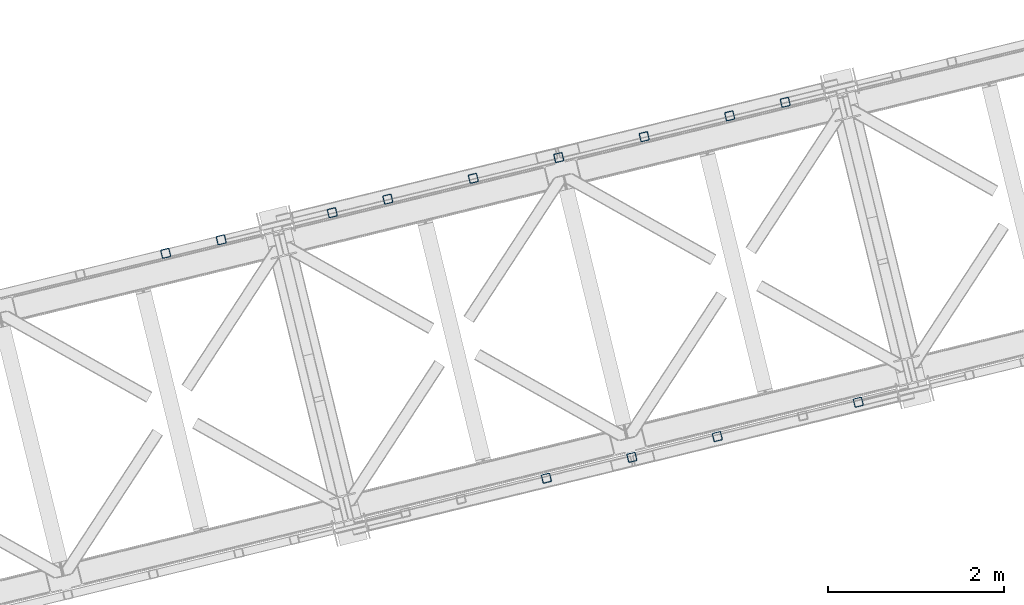
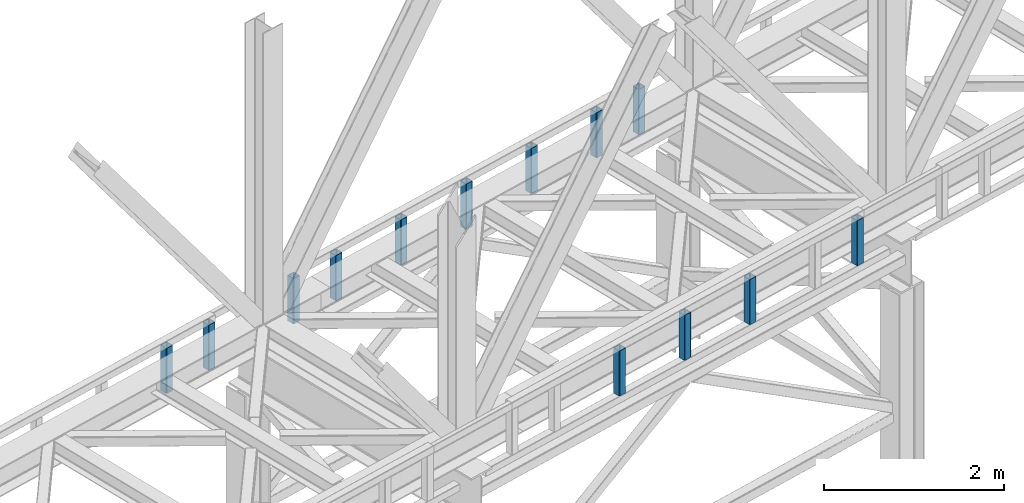
# One storey, part 7 of 93: 13 columns.
"""IFC4 building model written with IfcOpenShell, lengths in millimetres."""

from ifc_helpers import new_model, entity, si_unit, converted_unit, derived_unit, direction, frame, origin, place, context, subcontext, project, spatial, indexed_curve, outline, extrude, type_object, element, save


model = new_model("IFC4")

# Units and contexts
model_context = context("Model", 3, precision=0.01, world=origin(), true_north=direction((6.12303176911189e-17, 1.0)))
plan_context = context("Plan", 3, precision=0.01, world=origin(), true_north=direction((6.12303176911189e-17, 1.0)))
body_context = subcontext(model_context, "Body", "Model", "MODEL_VIEW")
ifc_project = project(units=[si_unit("LENGTHUNIT", "METRE", prefix="MILLI"), si_unit("AREAUNIT", "SQUARE_METRE"), si_unit("VOLUMEUNIT", "CUBIC_METRE"), converted_unit("PLANEANGLEUNIT", "DEGREE", entity("IfcRatioMeasure", 0.0174532925199433), si_unit("PLANEANGLEUNIT", "RADIAN"), dimensions=[0, 0, 0, 0, 0, 0, 0]), si_unit("MASSUNIT", "GRAM", prefix="KILO"), derived_unit("MASSDENSITYUNIT", [(si_unit("MASSUNIT", "GRAM", prefix="KILO"), 1), (si_unit("LENGTHUNIT", "METRE"), -3)]), derived_unit("MOMENTOFINERTIAUNIT", [(si_unit("LENGTHUNIT", "METRE"), 4)]), si_unit("TIMEUNIT", "SECOND"), si_unit("FREQUENCYUNIT", "HERTZ"), si_unit("THERMODYNAMICTEMPERATUREUNIT", "DEGREE_CELSIUS"), derived_unit("THERMALTRANSMITTANCEUNIT", [(si_unit("MASSUNIT", "GRAM", prefix="KILO"), 1), (si_unit("THERMODYNAMICTEMPERATUREUNIT", "KELVIN"), -1), (si_unit("TIMEUNIT", "SECOND"), -3)]), derived_unit("VOLUMETRICFLOWRATEUNIT", [(si_unit("LENGTHUNIT", "METRE"), 3), (si_unit("TIMEUNIT", "SECOND"), -1)]), derived_unit("MASSFLOWRATEUNIT", [(si_unit("MASSUNIT", "GRAM", prefix="KILO"), 1), (si_unit("TIMEUNIT", "SECOND"), -1)]), derived_unit("ROTATIONALFREQUENCYUNIT", [(si_unit("TIMEUNIT", "SECOND"), -1)]), si_unit("ELECTRICCURRENTUNIT", "AMPERE"), si_unit("ELECTRICVOLTAGEUNIT", "VOLT"), si_unit("POWERUNIT", "WATT"), si_unit("FORCEUNIT", "NEWTON", prefix="KILO"), si_unit("ILLUMINANCEUNIT", "LUX"), si_unit("LUMINOUSFLUXUNIT", "LUMEN"), si_unit("LUMINOUSINTENSITYUNIT", "CANDELA"), derived_unit("USERDEFINED", [(si_unit("MASSUNIT", "GRAM", prefix="KILO"), -1), (si_unit("LENGTHUNIT", "METRE"), -2), (si_unit("TIMEUNIT", "SECOND"), 3), (si_unit("LUMINOUSFLUXUNIT", "LUMEN"), 1)]), derived_unit("LINEARVELOCITYUNIT", [(si_unit("LENGTHUNIT", "METRE"), 1), (si_unit("TIMEUNIT", "SECOND"), -1)]), si_unit("PRESSUREUNIT", "PASCAL"), derived_unit("USERDEFINED", [(si_unit("LENGTHUNIT", "METRE"), -2), (si_unit("MASSUNIT", "GRAM", prefix="KILO"), 1), (si_unit("TIMEUNIT", "SECOND"), -2)]), derived_unit("LINEARFORCEUNIT", [(si_unit("MASSUNIT", "GRAM", prefix="KILO"), 1), (si_unit("LENGTHUNIT", "METRE"), 1), (si_unit("TIMEUNIT", "SECOND"), -2), (si_unit("LENGTHUNIT", "METRE"), -1)]), derived_unit("PLANARFORCEUNIT", [(si_unit("MASSUNIT", "GRAM", prefix="KILO"), 1), (si_unit("LENGTHUNIT", "METRE"), 1), (si_unit("TIMEUNIT", "SECOND"), -2), (si_unit("LENGTHUNIT", "METRE"), -2)])], contexts=[model_context, plan_context])

# Site, building, storey
site_placement = place(None, origin())
site = spatial("IfcSite", under=ifc_project, at=site_placement, CompositionType="ELEMENT")
building_placement = place(site_placement, origin())
building = spatial("IfcBuilding", under=site, at=building_placement, CompositionType="ELEMENT")
storey_placement = place(building_placement, frame((0.0, 0.0, 15900.0)))
storey = spatial("IfcBuildingStorey", under=building, at=storey_placement, CompositionType="ELEMENT", Elevation=15900.0)

# Columns
column_type_1 = type_object("IfcColumnType", PredefinedType="COLUMN")
column_1_placement = place(storey_placement, origin())
element("IfcColumn", 1, at=column_1_placement, inside=storey, type_object=column_type_1, ObjectType="Steel Column", PredefinedType="COLUMN", context=body_context, shape_type="SweptSolid", body=[
    extrude(outline(indexed_curve([(29.4768951153029, -56.8428769008198), (33.3787015556228, -56.8428769008198), (36.9835006656554, -55.3497202198148), (39.7424944584929, -52.5907264269884), (41.2356511394991, -48.9859273169536), (56.84287690082, 29.4768951152981), (56.8428769008277, 33.3787015556192), (55.3497202198129, 36.9835006656563), (52.5907264269925, 39.7424944584862), (48.9859273169586, 41.2356511394944), (-29.4768951152941, 56.8428769008181), (-33.3787015556141, 56.8428769008181), (-36.9835006656505, 55.349720219815), (-39.7424944584793, 52.5907264269869), (-41.2356511394904, 48.9859273169519), (-56.8428769008112, -29.4768951152997), (-56.842876900815, -33.3787015556227), (-55.3497202198089, -36.9835006656581), (-52.5907264269837, -39.7424944584879), (-48.9859273169498, -41.2356511394961), (29.4768951153029, -56.8428769008198)], self_intersect=False), holes=[indexed_curve([(-43.1065493048517, -37.307176347563), (-46.7113484148808, -35.8140196665547), (-49.4703422077117, -33.0550258737269), (-50.963498888713, -29.4502267636914), (-50.963498888714, -25.5484203233686), (-37.3071763475533, 43.106549304852), (-35.8140196665462, 46.7113484148888), (-33.0550258737174, 49.4703422077169), (-29.4502267636801, 50.963498888722), (-25.548420323361, 50.96349888872), (43.1065493048614, 37.3071763475633), (46.7113484148896, 35.814019666553), (49.4703422077244, 33.0550258737234), (50.9634988887296, 29.4502267636861), (50.9634988887306, 25.5484203233633), (37.3071763475739, -43.1065493048592), (35.8140196665589, -46.7113484148923), (33.0550258737234, -49.4703422077244), (29.4502267636897, -50.9634988887217), (25.5484203233707, -50.9634988887198), (-43.1065493048517, -37.307176347563)], self_intersect=False)]), frame((-37205.5668892731, 11928.9535059797, 3168.0), z_axis=(0.0, 0.0, 1.0), x_axis=(0.906681479027134, 0.421815949898968, 0.0)), (0.0, 0.0, 1.0), 612.000000000008),
])
column_type_2 = type_object("IfcColumnType", PredefinedType="COLUMN")
column_2_placement = place(storey_placement, origin())
element("IfcColumn", 2, at=column_2_placement, inside=storey, type_object=column_type_2, ObjectType="Steel Column", PredefinedType="COLUMN", context=body_context, shape_type="SweptSolid", body=[
    extrude(outline(indexed_curve([(29.4768951152981, -56.84287690082), (33.378701555618, -56.84287690082), (36.9835006656544, -55.3497202198168), (39.7424944584841, -52.5907264269867), (41.2356511394982, -48.9859273169556), (56.84287690082, 29.4768951152981), (56.8428769008189, 33.3787015556209), (55.3497202198129, 36.9835006656563), (52.5907264269877, 39.7424944584861), (48.9859273169538, 41.2356511394943), (-29.476895115299, 56.842876900818), (-33.3787015556189, 56.842876900818), (-36.9835006656602, 55.3497202198147), (-39.7424944584841, 52.5907264269867), (-41.2356511394952, 48.9859273169518), (-56.8428769008161, -29.4768951152999), (-56.8428769008198, -33.3787015556229), (-55.3497202198186, -36.9835006656584), (-52.5907264269886, -39.742494458488), (-48.9859273169547, -41.2356511394962), (29.4768951152981, -56.84287690082)], self_intersect=False), holes=[indexed_curve([(-43.1065493048575, -37.3071763475651), (-46.7113484148856, -35.8140196665548), (-49.4703422077187, -33.0550258737213), (-50.9634988887217, -29.4502267636897), (-50.9634988887228, -25.5484203233669), (-37.3071763475621, 43.1065493048537), (-35.8140196665549, 46.7113484148905), (-33.0550258737289, 49.4703422077126), (-29.4502267636858, 50.9634988887199), (-25.5484203233668, 50.9634988887179), (43.1065493048557, 37.3071763475612), (46.7113484148847, 35.8140196665528), (49.4703422077138, 33.0550258737212), (50.9634988887199, 29.4502267636858), (50.9634988887219, 25.548420323365), (37.3071763475612, -43.1065493048557), (35.8140196665501, -46.7113484148906), (33.0550258737223, -49.4703422077167), (29.450226763684, -50.9634988887238), (25.548420323365, -50.9634988887219), (-43.1065493048575, -37.3071763475651)], self_intersect=False)]), frame((-37837.075727065, 11775.016545536, 3168.0), z_axis=(0.0, 0.0, 1.0), x_axis=(0.906681479027134, 0.421815949898968, 0.0)), (0.0, 0.0, 1.0), 612.000000000008),
])
column_type_3 = type_object("IfcColumnType", PredefinedType="COLUMN")
column_3_placement = place(storey_placement, origin())
element("IfcColumn", 3, at=column_3_placement, inside=storey, type_object=column_type_3, ObjectType="Steel Column", PredefinedType="COLUMN", context=body_context, shape_type="SweptSolid", body=[
    extrude(outline(indexed_curve([(29.4768951153059, -56.8428769008236), (33.3787015556259, -56.8428769008236), (36.9835006656662, -55.3497202198223), (39.7424944584998, -52.5907264269941), (41.235651139507, -48.9859273169573), (56.8428769008318, 29.4768951152926), (56.8428769008355, 33.3787015556155), (55.3497202198246, 36.9835006656508), (52.5907264269916, 39.7424944584842), (48.9859273169616, 41.2356511394906), (-29.4768951152911, 56.8428769008144), (-33.3787015556111, 56.8428769008144), (-36.9835006656436, 55.3497202198093), (-39.7424944584723, 52.5907264269813), (-41.2356511394873, 48.9859273169481), (-56.8428769008082, -29.4768951153035), (-56.8428769008071, -33.3787015556264), (-55.349720219802, -36.9835006656637), (-52.5907264269807, -39.7424944584917), (-48.9859273169468, -41.2356511394999), (29.4768951153059, -56.8428769008236)], self_intersect=False), holes=[indexed_curve([(-43.1065493048478, -37.3071763475648), (-46.7113484148729, -35.8140196665583), (-49.4703422077021, -33.0550258737267), (-50.9634988887051, -29.4502267636951), (-50.9634988887053, -25.5484203233703), (-37.3071763475464, 43.1065493048464), (-35.8140196665383, 46.7113484148851), (-33.0550258737096, 49.4703422077132), (-29.450226763677, 50.9634988887182), (-25.5484203233571, 50.9634988887182), (43.1065493048644, 37.3071763475595), (46.7113484149032, 35.8140196665514), (49.4703422077305, 33.0550258737158), (50.9634988887326, 29.4502267636823), (50.9634988887385, 25.5484203233596), (37.3071763475778, -43.106549304861), (35.8140196665685, -46.711348414892), (33.0550258737389, -49.4703422077221), (29.4502267636928, -50.9634988887255), (25.5484203233737, -50.9634988887236), (-43.1065493048478, -37.3071763475648)], self_intersect=False)]), frame((-38808.6277852065, 11538.1904525456, 3168.0), z_axis=(0.0, 0.0, 1.0), x_axis=(0.906681479027134, 0.421815949898968, 0.0)), (0.0, 0.0, 1.0), 612.000000000008),
])
column_type_4 = type_object("IfcColumnType", PredefinedType="COLUMN")
column_4_placement = place(storey_placement, origin())
element("IfcColumn", 4, at=column_4_placement, inside=storey, type_object=column_type_4, ObjectType="Steel Column", PredefinedType="COLUMN", context=body_context, shape_type="SweptSolid", body=[
    extrude(outline(indexed_curve([(29.4768951152932, -56.8428769008201), (33.3787015556132, -56.8428769008201), (36.9835006656584, -55.3497202198186), (39.7424944584832, -52.5907264269887), (41.2356511394894, -48.9859273169539), (56.8428769008112, 29.4768951152998), (56.8428769008189, 33.3787015556209), (55.3497202198129, 36.9835006656563), (52.5907264269789, 39.7424944584878), (48.985927316945, 41.235651139496), (-29.4768951153029, 56.8428769008198), (-33.3787015556228, 56.8428769008198), (-36.9835006656602, 55.3497202198147), (-39.7424944584929, 52.5907264269884), (-41.2356511394991, 48.9859273169536), (-56.8428769008209, -29.4768951153001), (-56.8428769008198, -33.3787015556229), (-55.3497202198225, -36.9835006656566), (-52.5907264269886, -39.7424944584881), (-48.9859273169547, -41.2356511394963), (29.4768951152932, -56.8428769008201)], self_intersect=False), holes=[indexed_curve([(-43.1065493048575, -37.3071763475651), (-46.7113484148905, -35.814019666555), (-49.4703422077244, -33.0550258737235), (-50.9634988887217, -29.4502267636898), (-50.9634988887228, -25.5484203233669), (-37.3071763475621, 43.1065493048537), (-35.8140196665628, 46.7113484148941), (-33.0550258737223, 49.4703422077167), (-29.4502267636937, 50.9634988887235), (-25.5484203233746, 50.9634988887216), (43.1065493048557, 37.3071763475612), (46.7113484148808, 35.8140196665547), (49.4703422077157, 33.0550258737252), (50.9634988887199, 29.4502267636858), (50.963498888714, 25.5484203233686), (37.3071763475612, -43.1065493048556), (35.8140196665471, -46.7113484148868), (33.0550258737117, -49.4703422077189), (29.450226763684, -50.9634988887238), (25.548420323365, -50.9634988887219), (-43.1065493048575, -37.3071763475651)], self_intersect=False)]), frame((-39780.179843348, 11301.3643595553, 3168.0), z_axis=(0.0, 0.0, 1.0), x_axis=(0.906681479027134, 0.421815949898968, 0.0)), (0.0, 0.0, 1.0), 612.000000000008),
])
column_type_5 = type_object("IfcColumnType", PredefinedType="COLUMN")
column_5_placement = place(storey_placement, origin())
element("IfcColumn", 5, at=column_5_placement, inside=storey, type_object=column_type_5, ObjectType="Steel Column", PredefinedType="COLUMN", context=body_context, shape_type="SweptSolid", body=[
    extrude(outline(indexed_curve([(29.4768951153483, -56.8428769007886), (33.3787015556761, -56.8428769007886), (36.9835006657111, -55.349720219782), (39.7424944585412, -52.5907264269532), (41.235651139545, -48.985927316915), (56.8428769007924, 29.4768951153513), (56.8428769007886, 33.3787015556761), (55.3497202197791, 36.9835006657101), (52.5907264269514, 39.7424944585373), (48.985927316916, 41.2356511395421), (-29.4768951153474, 56.8428769007905), (-33.3787015556752, 56.8428769007905), (-36.9835006657111, 55.349720219782), (-39.7424944585412, 52.5907264269532), (-41.2356511395362, 48.9859273169133), (-56.8428769007924, -29.4768951153513), (-56.8428769007886, -33.3787015556761), (-55.3497202197782, -36.9835006657081), (-52.5907264269504, -39.7424944585353), (-48.9859273169151, -41.2356511395401), (29.4768951153483, -56.8428769007886)], self_intersect=False), holes=[indexed_curve([(-43.1065493048216, -37.3071763476035), (-46.7113484148569, -35.8140196665987), (-49.4703422076838, -33.0550258737695), (-50.9634988886854, -29.4502267637392), (-50.9634988886901, -25.5484203234163), (-37.3071763475946, 43.1065493048151), (-35.8140196665917, 46.7113484148513), (-33.0550258737598, 49.4703422076841), (-29.4502267637405, 50.9634988886979), (-25.5484203234214, 50.9634988886996), (43.1065493048216, 37.3071763476035), (46.711348414863, 35.8140196665911), (49.4703422076926, 33.0550258737678), (50.963498888702, 29.4502267637338), (50.9634988887067, 25.548420323411), (37.3071763476103, -43.1065493048224), (35.8140196665996, -46.711348414855), (33.0550258737686, -49.4703422076858), (29.4502267637405, -50.9634988886979), (25.5484203234136, -50.963498888696), (-43.1065493048216, -37.3071763476035)], self_intersect=False)]), frame((-40751.7319014895, 11064.5382665649, 3168.0), z_axis=(0.0, 0.0, 1.0), x_axis=(0.906681479027529, 0.421815949898119, 0.0)), (0.0, 0.0, 1.0), 612.000000000008),
])
column_type_6 = type_object("IfcColumnType", PredefinedType="COLUMN")
column_6_placement = place(storey_placement, origin())
element("IfcColumn", 6, at=column_6_placement, inside=storey, type_object=column_type_6, ObjectType="Steel Column", PredefinedType="COLUMN", context=body_context, shape_type="SweptSolid", body=[
    extrude(outline(indexed_curve([(29.476895115376, -56.8428769007757), (33.3787015557029, -56.8428769007757), (36.9835006657302, -55.3497202197617), (39.7424944585589, -52.5907264269315), (41.23565113956, -48.9859273168945), (56.8428769007766, 29.4768951153779), (56.8428769007709, 33.3787015557027), (55.3497202197596, 36.983500665736), (52.5907264269295, 39.7424944585598), (48.9859273168944, 41.2356511395648), (-29.4768951153857, 56.8428769007754), (-33.3787015557135, 56.8428769007735), (-36.9835006657399, 55.3497202197614), (-39.7424944585686, 52.5907264269312), (-41.2356511395706, 48.9859273168923), (-56.8428769007872, -29.4768951153802), (-56.8428769007727, -33.3787015557067), (-55.3497202197693, -36.9835006657362), (-52.5907264269401, -39.7424944585621), (-48.9859273169041, -41.2356511395651), (29.476895115376, -56.8428769007757)], self_intersect=False), holes=[indexed_curve([(-43.106549304795, -37.3071763476288), (-46.711348414838, -35.8140196666202), (-49.4703422076759, -33.0550258737927), (-50.9634988886802, -29.4502267637651), (-50.963498888686, -25.5484203234403), (-37.3071763476251, 43.106549304798), (-35.8140196666231, 46.7113484148369), (-33.0550258737953, 49.4703422076652), (-29.4502267637661, 50.9634988886831), (-25.5484203234392, 50.9634988886831), (43.1065493047941, 37.3071763476269), (46.711348414838, 35.8140196666202), (49.4703422076672, 33.0550258737944), (50.9634988886784, 29.4502267637612), (50.9634988886851, 25.5484203234383), (37.3071763476232, -43.1065493048019), (35.8140196666213, -46.7113484148409), (33.0550258737944, -49.4703422076672), (29.4502267637661, -50.9634988886831), (25.5484203234383, -50.9634988886851), (-43.106549304795, -37.3071763476288)], self_intersect=False)]), frame((-41723.2839596309, 10827.7121735746, 3168.0), z_axis=(0.0, 0.0, 1.0), x_axis=(0.906681479027741, 0.421815949897663, 0.0)), (0.0, 0.0, 1.0), 612.000000000008),
])
column_type_7 = type_object("IfcColumnType", PredefinedType="COLUMN")
column_7_placement = place(storey_placement, origin())
element("IfcColumn", 7, at=column_7_placement, inside=storey, type_object=column_type_7, ObjectType="Steel Column", PredefinedType="COLUMN", context=body_context, shape_type="SweptSolid", body=[
    extrude(outline(indexed_curve([(29.4768951153089, -56.8428769008274), (33.3787015556289, -56.8428769008274), (36.9835006656662, -55.3497202198223), (39.7424944584989, -52.590726426996), (41.2356511395051, -48.9859273169612), (56.8428769008269, 29.4768951152924), (56.8428769008337, 33.3787015556116), (55.3497202198277, 36.983500665647), (52.5907264269946, 39.7424944584805), (48.9859273169607, 41.2356511394887), (-29.4768951152881, 56.8428769008106), (-33.3787015556159, 56.8428769008142), (-36.9835006656445, 55.3497202198074), (-39.7424944584772, 52.5907264269811), (-41.2356511394843, 48.9859273169444), (-56.842876900814, -29.4768951153056), (-56.8428769008129, -33.3787015556285), (-55.3497202198068, -36.9835006656639), (-52.5907264269816, -39.7424944584937), (-48.9859273169477, -41.2356511395018), (29.4768951153089, -56.8428769008274)], self_intersect=False), holes=[indexed_curve([(-43.1065493048496, -37.3071763475687), (-46.7113484148826, -35.8140196665586), (-49.4703422077175, -33.0550258737291), (-50.9634988887148, -29.4502267636954), (-50.9634988887071, -25.5484203233742), (-37.3071763475551, 43.1065493048481), (-35.8140196665411, 46.7113484148792), (-33.0550258737144, 49.4703422077131), (-29.4502267636867, 50.9634988887179), (-25.5484203233668, 50.9634988887179), (43.1065493048547, 37.3071763475592), (46.7113484148974, 35.8140196665493), (49.4703422077305, 33.0550258737158), (50.9634988887287, 29.4502267636841), (50.9634988887288, 25.5484203233593), (37.3071763475681, -43.1065493048613), (35.814019666561, -46.7113484148981), (33.0550258737223, -49.4703422077167), (29.4502267636918, -50.9634988887275), (25.5484203233719, -50.9634988887275), (-43.1065493048496, -37.3071763475687)], self_intersect=False)]), frame((-42354.7927974229, 10673.7752131309, 3168.0), z_axis=(0.0, 0.0, 1.0), x_axis=(0.906681479027134, 0.421815949898968, 0.0)), (0.0, 0.0, 1.0), 612.000000000008),
])
column_type_8 = type_object("IfcColumnType", PredefinedType="COLUMN")
column_8_placement = place(storey_placement, origin())
element("IfcColumn", 8, at=column_8_placement, inside=storey, type_object=column_type_8, ObjectType="Steel Column", PredefinedType="COLUMN", context=body_context, shape_type="SweptSolid", body=[
    extrude(outline(indexed_curve([(29.4768951153552, -56.8428769007942), (33.378701555683, -56.8428769007942), (36.983500665719, -55.3497202197857), (39.7424944585412, -52.5907264269532), (41.2356511395441, -48.985927316917), (56.8428769008002, 29.4768951153476), (56.8428769007964, 33.3787015556724), (55.349720219787, 36.9835006657064), (52.5907264269583, 39.7424944585317), (48.9859273169151, 41.2356511395401), (-29.4768951153474, 56.8428769007906), (-33.3787015556673, 56.8428769007869), (-36.9835006657033, 55.3497202197784), (-39.7424944585334, 52.5907264269495), (-41.2356511395371, 48.9859273169114), (-56.8428769007845, -29.4768951153549), (-56.8428769007807, -33.3787015556797), (-55.3497202197713, -36.9835006657137), (-52.5907264269426, -39.742494458539), (-48.9859273169082, -41.2356511395457), (29.4768951153552, -56.8428769007942)], self_intersect=False), holes=[indexed_curve([(-43.1065493048138, -37.3071763476071), (-46.711348414856, -35.8140196665967), (-49.4703422076856, -33.0550258737734), (-50.9634988886863, -29.4502267637411), (-50.9634988886832, -25.5484203234219), (-37.3071763475946, 43.1065493048151), (-35.8140196665917, 46.7113484148513), (-33.0550258737607, 49.4703422076821), (-29.4502267637335, 50.9634988886923), (-25.5484203234136, 50.963498888696), (43.1065493048129, 37.3071763476052), (46.7113484148648, 35.814019666595), (49.4703422076917, 33.0550258737658), (50.9634988887011, 29.4502267637318), (50.9634988887058, 25.548420323409), (37.3071763476094, -43.1065493048244), (35.8140196665978, -46.7113484148589), (33.0550258737686, -49.4703422076858), (29.4502267637317, -50.9634988886963), (25.5484203234205, -50.9634988887016), (-43.1065493048138, -37.3071763476071)], self_intersect=False)]), frame((-43617.8104730068, 10365.9012922435, 3168.0), z_axis=(0.0, 0.0, 1.0), x_axis=(0.906681479027529, 0.421815949898119, 0.0)), (0.0, 0.0, 1.0), 612.000000000008),
])
column_type_9 = type_object("IfcColumnType", PredefinedType="COLUMN")
column_9_placement = place(storey_placement, origin())
element("IfcColumn", 9, at=column_9_placement, inside=storey, type_object=column_type_9, ObjectType="Steel Column", PredefinedType="COLUMN", context=body_context, shape_type="SweptSolid", body=[
    extrude(outline(indexed_curve([(29.4768951153257, -56.842876900811), (33.3787015556544, -56.842876900811), (36.9835006656902, -55.3497202198063), (39.7424944585138, -52.5907264269752), (41.2356511395273, -48.9859273169414), (56.8428769008141, 29.476895115317), (56.8428769008123, 33.3787015556418), (55.3497202198047, 36.9835006656766), (52.5907264269783, 39.7424944585052), (48.9859273169437, 41.2356511395118), (-29.4768951153197, 56.8428769008034), (-33.3787015556396, 56.8428769008018), (-36.9835006656763, 55.349720219795), (-39.7424944585078, 52.5907264269676), (-41.2356511395125, 48.9859273169321), (-56.8428769008003, -29.4768951153283), (-56.8428769007984, -33.3787015556531), (-55.3497202197899, -36.9835006656858), (-52.5907264269635, -39.7424944585144), (-48.9859273169289, -41.2356511395211), (29.4768951153257, -56.842876900811)], self_intersect=False), holes=[indexed_curve([(-43.1065493048256, -37.307176347591), (-46.711348414875, -35.8140196665751), (-49.4703422077023, -33.0550258737485), (-50.9634988886942, -29.4502267637211), (-50.963498888696, -25.5484203233963), (-37.307176347565, 43.1065493048302), (-35.8140196665682, 46.7113484148694), (-33.0550258737367, 49.4703422076968), (-29.4502267637088, 50.9634988887052), (-25.5484203233879, 50.9634988887089), (43.1065493048395, 37.3071763475798), (46.7113484148819, 35.8140196665695), (49.4703422077074, 33.0550258737389), (50.9634988887238, 29.4502267637025), (50.9634988887177, 25.5484203233814), (37.3071763475955, -43.1065493048468), (35.8140196665743, -46.711348414877), (33.0550258737428, -49.4703422077044), (29.4502267637139, -50.9634988887148), (25.5484203234018, -50.9634988887201), (-43.1065493048256, -37.307176347591)], self_intersect=False)]), frame((-44249.3193107988, 10211.9643317997, 3168.0), z_axis=(0.0, 0.0, 1.0), x_axis=(0.906681479027317, 0.421815949898576, 0.0)), (0.0, 0.0, 1.0), 612.000000000008),
])
column_type_10 = type_object("IfcColumnType", PredefinedType="COLUMN")
column_10_placement = place(storey_placement, origin())
element("IfcColumn", 10, at=column_10_placement, inside=storey, type_object=column_type_10, ObjectType="Steel Column", PredefinedType="COLUMN", context=body_context, shape_type="SweptSolid", body=[
    extrude(outline(indexed_curve([(29.4768951153054, -56.8428769008069), (33.3787015556249, -56.8428769008069), (36.9835006656614, -55.3497202198019), (39.7424944584899, -52.5907264269721), (41.2356511394992, -48.9859273169387), (56.8428769008008, 29.4768951153178), (56.8428769008031, 33.3787015556398), (55.3497202197966, 36.9835006656758), (52.5907264269663, 39.7424944585058), (48.9859273169364, 41.2356511395122), (-29.4768951153202, 56.8428769008162), (-33.3787015556436, 56.842876900818), (-36.9835006656723, 55.3497202198093), (-39.7424944585091, 52.5907264269822), (-41.235651139514, 48.985927316948), (-56.842876900816, -29.4768951153096), (-56.8428769008228, -33.3787015556307), (-55.349720219807, -36.9835006656674), (-52.5907264269855, -39.7424944584957), (-48.9859273169512, -41.2356511395029), (29.4768951153054, -56.8428769008069)], self_intersect=False), holes=[indexed_curve([(-43.1065493048546, -37.3071763475693), (-46.7113484148879, -35.8140196665601), (-49.4703422077196, -33.0550258737331), (-50.9634988887261, -29.4502267636971), (-50.9634988887268, -25.5484203233713), (-37.3071763475882, 43.1065493048526), (-35.8140196665741, 46.7113484148861), (-33.0550258737398, 49.4703422077179), (-29.45022676371, 50.963498888719), (-25.5484203233861, 50.9634988887181), (43.1065493048349, 37.3071763475785), (46.7113484148692, 35.8140196665712), (49.4703422077004, 33.0550258737432), (50.9634988887025, 29.450226763708), (50.9634988887041, 25.5484203233842), (37.3071763475611, -43.1065493048388), (35.8140196665554, -46.711348414875), (33.0550258737225, -49.4703422077039), (29.4502267636903, -50.9634988887098), (25.5484203233704, -50.9634988887108), (-43.1065493048546, -37.3071763475693)], self_intersect=False)]), frame((-36374.54412897, 8519.77733396126, 3168.0), z_axis=(0.0, 0.0, 1.0), x_axis=(-0.90668147902724, -0.42181594989874, 0.0)), (0.0, 0.0, 1.0), 612.000000000008),
])
column_type_11 = type_object("IfcColumnType", PredefinedType="COLUMN")
column_11_placement = place(storey_placement, origin())
element("IfcColumn", 11, at=column_11_placement, inside=storey, type_object=column_type_11, ObjectType="Steel Column", PredefinedType="COLUMN", context=body_context, shape_type="SweptSolid", body=[
    extrude(outline(indexed_curve([(29.4768951153098, -56.8428769008078), (33.3787015556293, -56.8428769008078), (36.9835006656619, -55.3497202198009), (39.7424944584899, -52.5907264269721), (41.2356511395036, -48.9859273169396), (56.8428769008056, 29.476895115318), (56.8428769008036, 33.3787015556408), (55.3497202197966, 36.9835006656758), (52.5907264269751, 39.7424944585041), (48.9859273169408, 41.2356511395114), (-29.4768951153158, 56.8428769008154), (-33.3787015556353, 56.8428769008154), (-36.9835006656762, 55.3497202198111), (-39.7424944585091, 52.5907264269822), (-41.2356511395184, 48.9859273169489), (-56.84287690082, -29.4768951153077), (-56.8428769008223, -33.3787015556297), (-55.3497202198114, -36.9835006656666), (-52.5907264269767, -39.7424944584974), (-48.9859273169464, -41.2356511395028), (29.4768951153098, -56.8428769008078)], self_intersect=False), holes=[indexed_curve([(-43.1065493048497, -37.3071763475692), (-46.7113484148898, -35.814019666564), (-49.4703422077173, -33.0550258737282), (-50.9634988887199, -29.450226763694), (-50.9634988887263, -25.5484203233703), (-37.3071763475838, 43.1065493048517), (-35.814019666575, 46.7113484148841), (-33.0550258737456, 49.4703422077158), (-29.4502267637047, 50.9634988887201), (-25.5484203233812, 50.9634988887182), (43.1065493048393, 37.3071763475776), (46.7113484148727, 35.8140196665684), (49.4703422076986, 33.0550258737393), (50.963498888703, 29.450226763709), (50.9634988887037, 25.5484203233833), (37.307176347562, -43.1065493048369), (35.8140196665558, -46.711348414874), (33.0550258737229, -49.4703422077029), (29.4502267636952, -50.9634988887097), (25.5484203233752, -50.9634988887107), (-43.1065493048497, -37.3071763475692)], self_intersect=False)]), frame((-37977.6050249034, 8129.0142805272, 3168.0), z_axis=(0.0, 0.0, 1.0), x_axis=(-0.90668147902724, -0.42181594989874, 0.0)), (0.0, 0.0, 1.0), 612.000000000008),
])
column_type_12 = type_object("IfcColumnType", PredefinedType="COLUMN")
column_12_placement = place(storey_placement, origin())
element("IfcColumn", 12, at=column_12_placement, inside=storey, type_object=column_type_12, ObjectType="Steel Column", PredefinedType="COLUMN", context=body_context, shape_type="SweptSolid", body=[
    extrude(outline(indexed_curve([(29.4768951153089, -56.8428769008097), (33.3787015556284, -56.8428769008097), (36.9835006656654, -55.3497202198037), (39.7424944584934, -52.5907264269749), (41.2356511395027, -48.9859273169415), (56.8428769008047, 29.476895115316), (56.842876900807, 33.378701555638), (55.3497202198001, 36.983500665673), (52.5907264269742, 39.7424944585021), (48.9859273169399, 41.2356511395094), (-29.4768951153167, 56.8428769008134), (-33.3787015556362, 56.8428769008134), (-36.9835006656771, 55.3497202198092), (-39.7424944585056, 52.5907264269794), (-41.2356511395105, 48.9859273169452), (-56.8428769008121, -29.4768951153114), (-56.8428769008188, -33.3787015556325), (-55.3497202198123, -36.9835006656685), (-52.5907264269816, -39.7424944584975), (-48.9859273169473, -41.2356511395048), (29.4768951153089, -56.8428769008097)], self_intersect=False), holes=[indexed_curve([(-43.1065493048506, -37.3071763475712), (-46.7113484148849, -35.8140196665639), (-49.4703422077078, -33.0550258737386), (-50.9634988887178, -29.4502267636998), (-50.9634988887198, -25.5484203233769), (-37.3071763475764, 43.1065493048471), (-35.814019666572, 46.7113484148803), (-33.0550258737368, 49.4703422077141), (-29.450226763706, 50.9634988887171), (-25.5484203233822, 50.9634988887163), (43.1065493048389, 37.3071763475766), (46.7113484148722, 35.8140196665674), (49.4703422077073, 33.0550258737376), (50.9634988887095, 29.4502267637024), (50.9634988887111, 25.5484203233786), (37.3071763475681, -43.1065493048444), (35.8140196665623, -46.7113484148806), (33.0550258737255, -49.4703422077077), (29.4502267636943, -50.9634988887116), (25.5484203233743, -50.9634988887126), (-43.1065493048506, -37.3071763475712)], self_intersect=False)]), frame((-38949.1570830449, 7892.18818753686, 3168.0), z_axis=(0.0, 0.0, 1.0), x_axis=(-0.90668147902724, -0.42181594989874, 0.0)), (0.0, 0.0, 1.0), 612.000000000008),
])
column_type_13 = type_object("IfcColumnType", PredefinedType="COLUMN")
column_13_placement = place(storey_placement, origin())
element("IfcColumn", 13, at=column_13_placement, inside=storey, type_object=column_type_13, ObjectType="Steel Column", PredefinedType="COLUMN", context=body_context, shape_type="SweptSolid", body=[
    extrude(outline(indexed_curve([(29.4768951153098, -56.8428769008255), (33.3787015556298, -56.8428769008255), (36.9835006656671, -55.3497202198203), (39.7424944585003, -52.5907264269931), (41.2356511395061, -48.9859273169592), (56.8428769008278, 29.4768951152944), (56.8428769008351, 33.3787015556146), (55.349720219829, 36.9835006656499), (52.5907264269955, 39.7424944584824), (48.9859273169621, 41.2356511394916), (-29.4768951152867, 56.8428769008135), (-33.3787015556145, 56.8428769008172), (-36.9835006656436, 55.3497202198093), (-39.7424944584767, 52.5907264269821), (-41.2356511394829, 48.9859273169473), (-56.8428769008121, -29.4768951153017), (-56.8428769008115, -33.3787015556255), (-55.3497202198055, -36.9835006656609), (-52.5907264269803, -39.7424944584907), (-48.9859273169385, -41.2356511395026), (29.4768951153098, -56.8428769008255)], self_intersect=False), holes=[indexed_curve([(-43.1065493048404, -37.3071763475695), (-46.7113484148813, -35.8140196665556), (-49.4703422077083, -33.0550258737298), (-50.9634988887139, -29.4502267636934), (-50.9634988887149, -25.5484203233706), (-37.3071763475542, 43.10654930485), (-35.8140196665484, 46.7113484148839), (-33.0550258737144, 49.4703422077131), (-29.450226763678, 50.9634988887163), (-25.5484203233502, 50.9634988887126), (43.1065493048714, 37.3071763475538), (46.7113484148979, 35.8140196665503), (49.4703422077221, 33.0550258737185), (50.9634988887291, 29.4502267636851), (50.9634988887288, 25.5484203233593), (37.3071763475695, -43.1065493048583), (35.8140196665637, -46.7113484148922), (33.0550258737296, -49.4703422077214), (29.4502267637006, -50.9634988887292), (25.5484203233811, -50.9634988887282), (-43.1065493048404, -37.3071763475695)], self_intersect=False)]), frame((-39920.7091411864, 7655.36209454652, 3168.0), z_axis=(0.0, 0.0, 1.0), x_axis=(-0.906681479027134, -0.421815949898968, 0.0)), (0.0, 0.0, 1.0), 612.000000000008),
])

save(model, "model.ifc")
